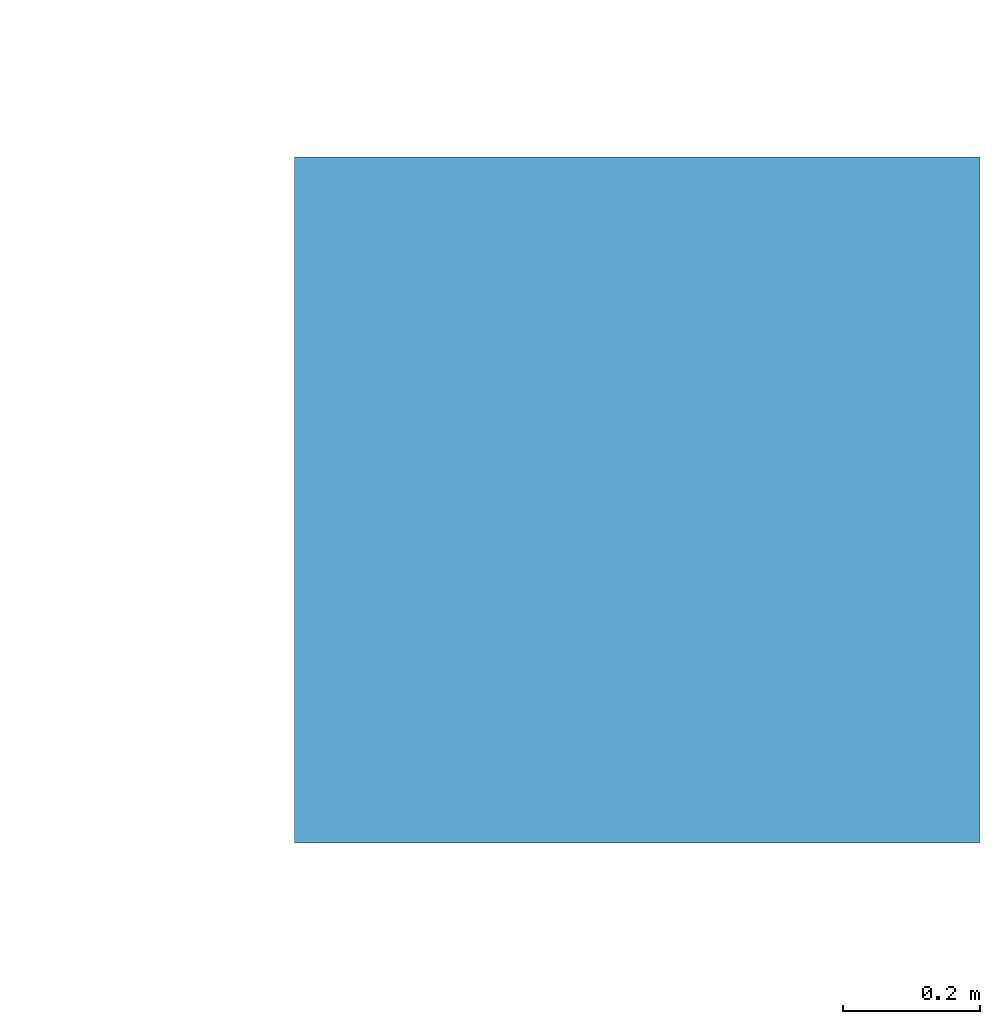
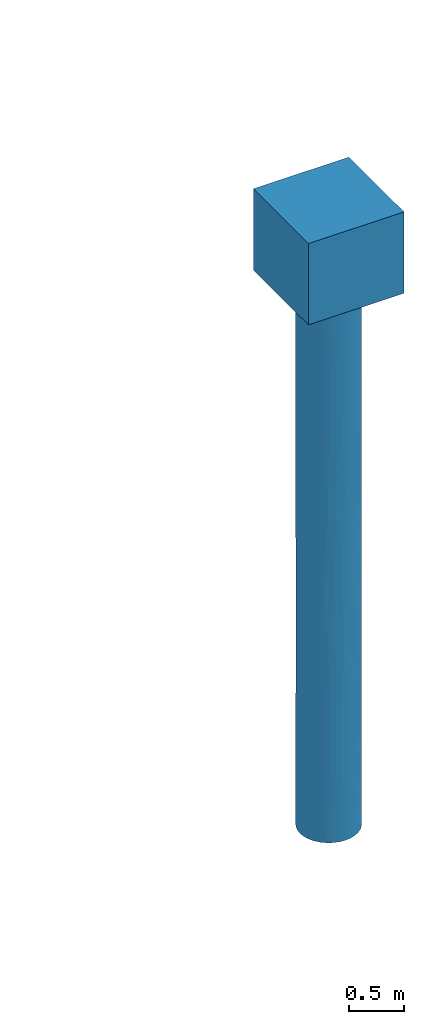
# One storey, part 2 of 2: 1 pile.
"""IFC4 building model written with IfcOpenShell, lengths in metres."""

from ifc_helpers import new_model, entity, si_unit, converted_unit, derived_unit, direction, frame, origin, place, context, subcontext, project, spatial, polygons, source, transform, mapped, material, type_object, type_shapes, element, save


model = new_model("IFC4")

# Units and contexts
model_context = context("Model", 3, precision=1e-05, world=origin(), true_north=direction((6.12303176911189e-17, 1.0)))
body_context = subcontext(model_context, "Body", "Model", "MODEL_VIEW")
ifc_project = project(units=[si_unit("LENGTHUNIT", "METRE"), si_unit("AREAUNIT", "SQUARE_METRE"), si_unit("VOLUMEUNIT", "CUBIC_METRE"), converted_unit("PLANEANGLEUNIT", "DEGREE", entity("IfcRatioMeasure", 0.0174532925199433), si_unit("PLANEANGLEUNIT", "RADIAN"), dimensions=[0, 0, 0, 0, 0, 0, 0]), si_unit("MASSUNIT", "GRAM", prefix="KILO"), derived_unit("MASSDENSITYUNIT", [(si_unit("MASSUNIT", "GRAM", prefix="KILO"), 1), (si_unit("LENGTHUNIT", "METRE"), -3)]), derived_unit("MOMENTOFINERTIAUNIT", [(si_unit("LENGTHUNIT", "METRE"), 4)]), si_unit("TIMEUNIT", "SECOND"), si_unit("FREQUENCYUNIT", "HERTZ"), si_unit("THERMODYNAMICTEMPERATUREUNIT", "DEGREE_CELSIUS"), derived_unit("THERMALTRANSMITTANCEUNIT", [(si_unit("MASSUNIT", "GRAM", prefix="KILO"), 1), (si_unit("THERMODYNAMICTEMPERATUREUNIT", "KELVIN"), -1), (si_unit("TIMEUNIT", "SECOND"), -3)]), derived_unit("VOLUMETRICFLOWRATEUNIT", [(si_unit("LENGTHUNIT", "METRE"), 3), (si_unit("TIMEUNIT", "SECOND"), -1)]), si_unit("ELECTRICCURRENTUNIT", "AMPERE"), si_unit("ELECTRICVOLTAGEUNIT", "VOLT"), si_unit("POWERUNIT", "WATT"), si_unit("FORCEUNIT", "NEWTON", prefix="KILO"), si_unit("ILLUMINANCEUNIT", "LUX"), si_unit("LUMINOUSFLUXUNIT", "LUMEN"), si_unit("LUMINOUSINTENSITYUNIT", "CANDELA"), derived_unit("USERDEFINED", [(si_unit("MASSUNIT", "GRAM", prefix="KILO"), -1), (si_unit("LENGTHUNIT", "METRE"), -2), (si_unit("TIMEUNIT", "SECOND"), 3), (si_unit("LUMINOUSFLUXUNIT", "LUMEN"), 1)]), derived_unit("LINEARVELOCITYUNIT", [(si_unit("LENGTHUNIT", "METRE"), 1), (si_unit("TIMEUNIT", "SECOND"), -1)]), si_unit("PRESSUREUNIT", "PASCAL"), derived_unit("USERDEFINED", [(si_unit("LENGTHUNIT", "METRE"), -2), (si_unit("MASSUNIT", "GRAM", prefix="KILO"), 1), (si_unit("TIMEUNIT", "SECOND"), -2)]), derived_unit("LINEARFORCEUNIT", [(si_unit("MASSUNIT", "GRAM", prefix="KILO"), 1), (si_unit("LENGTHUNIT", "METRE"), 1), (si_unit("TIMEUNIT", "SECOND"), -2), (si_unit("LENGTHUNIT", "METRE"), -1)]), derived_unit("PLANARFORCEUNIT", [(si_unit("MASSUNIT", "GRAM", prefix="KILO"), 1), (si_unit("LENGTHUNIT", "METRE"), 1), (si_unit("TIMEUNIT", "SECOND"), -2), (si_unit("LENGTHUNIT", "METRE"), -2)])], contexts=[model_context])

# Site, building, storey
site_placement = place(None, origin())
site = spatial("IfcSite", under=ifc_project, at=site_placement, CompositionType="ELEMENT")
building_placement = place(site_placement, origin())
building = spatial("IfcBuilding", under=site, at=building_placement, Name="1", CompositionType="ELEMENT")
storey_placement = place(building_placement, origin())
storey = spatial("IfcBuildingStorey", under=building, at=storey_placement, Name="1 korrus", CompositionType="ELEMENT", Elevation=0.0)

# Pile
ifc_material = material(Name="EST. C30/37", Category="Materials")
pile_type = type_object("IfcPileType", PredefinedType="NOTDEFINED", material=ifc_material)
shared_shape = source(origin(), body_context, "Body", "Tessellation", [
    polygons([(0.500000000000011, 0.5, 0.9), (-0.499999999999989, 0.5, 0.9), (-0.499999999999989, -0.5, 0.9), (0.500000000000011, -0.5, 0.9), (0.30000000000001, -1.96269667185334e-15, -6.0), (0.294235584120979, -0.0585270966048404, -6.0), (0.277163859753395, -0.114805029709529, -6.0), (0.249440883690773, -0.166671069905882, -6.0), (0.212132034355973, -0.212132034355965, -6.0), (0.166671069905889, -0.249440883690764, -6.0), (0.114805029709536, -0.277163859753387, -6.0), (0.0585270966048471, -0.294235584120969, -6.0), (8.86597462113059e-15, -0.3, -6.0), (-0.0585270966048297, -0.294235584120969, -6.0), (-0.114805029709518, -0.277163859753386, -6.0), (-0.166671069905872, -0.249440883690763, -6.0), (-0.212132034355955, -0.212132034355963, -6.0), (-0.249440883690754, -0.16667106990588, -6.0), (-0.277163859753376, -0.114805029709526, -6.0), (-0.294235584120959, -0.0585270966048374, -6.0), (-0.29999999999999, -9.47508738136094e-16, -6.0), (-0.294235584120959, 0.0585270966048374, -6.0), (-0.277163859753376, 0.114805029709526, -6.0), (-0.249440883690754, 0.16667106990588, -6.0), (-0.212132034355955, 0.212132034355963, -6.0), (-0.166671069905872, 0.249440883690763, -6.0), (-0.114805029709518, 0.277163859753386, -6.0), (-0.0585270966048297, 0.294235584120969, -6.0), (8.86597462113059e-15, 0.3, -6.0), (0.0585270966048471, 0.294235584120969, -6.0), (0.114805029709536, 0.277163859753387, -6.0), (0.166671069905889, 0.249440883690765, -6.0), (0.212132034355973, 0.212132034355965, -6.0), (0.249440883690773, 0.166671069905882, -6.0), (0.277163859753395, 0.114805029709529, -6.0), (0.294235584120979, 0.0585270966048404, -6.0), (0.500000000000011, 0.5, 0.0), (-0.499999999999989, 0.5, -1.35358391162299e-16), (-0.499999999999989, -0.5, -1.35358391162299e-16), (0.500000000000011, -0.5, -1.35358391162299e-16), (-0.29999999999999, -9.69326744659079e-16, 0.0), (-0.294235584120959, -0.0585270966048394, 0.0), (-0.277163859753375, -0.114805029709528, 0.0), (-0.249440883690753, -0.166671069905881, 0.0), (-0.212132034355954, -0.212132034355965, 0.0), (-0.16667106990587, -0.249440883690764, 0.0), (-0.114805029709516, -0.277163859753386, 0.0), (-0.0585270966048277, -0.294235584120969, 0.0), (1.06933129018216e-14, -0.3, 0.0), (0.0585270966048491, -0.294235584120969, 0.0), (0.114805029709537, -0.277163859753386, 0.0), (0.166671069905891, -0.249440883690763, 0.0), (0.212132034355975, -0.212132034355964, 0.0), (0.249440883690774, -0.166671069905881, 0.0), (0.277163859753396, -0.114805029709527, 0.0), (0.294235584120979, -0.0585270966048384, 0.0), (0.30000000000001, 1.93865348931914e-15, 0.0), (0.294235584120979, 0.0585270966048404, 0.0), (0.277163859753396, 0.114805029709529, 0.0), (0.249440883690773, 0.166671069905882, 0.0), (0.212132034355973, 0.212132034355965, 0.0), (0.166671069905889, 0.249440883690765, 0.0), (0.114805029709536, 0.277163859753387, 0.0), (0.0585270966048472, 0.294235584120969, 0.0), (8.83213502334002e-15, 0.3, 0.0), (-0.0585270966048297, 0.294235584120969, 0.0), (-0.114805029709518, 0.277163859753386, 0.0), (-0.166671069905872, 0.249440883690763, 0.0), (-0.212132034355955, 0.212132034355963, 0.0), (-0.249440883690754, 0.16667106990588, 0.0), (-0.277163859753376, 0.114805029709526, 0.0), (-0.294235584120959, 0.0585270966048375, 0.0), (0.30000000000001, 0.0, -3.58087616759201), (0.0294051411009087, -0.29855541809995, -2.99999999994958), (-0.29999999999999, -9.69326744659552e-16, -2.41912381490379), (0.231903134769796, -0.190317986758863, -2.60855789319398), (-0.190317985616317, -0.23190313570744, -3.21830624548826), (0.30000000000001, 0.0, -2.41912383240799), (0.141419020154583, -0.264576379781946, -4.19483481984957), (-0.0870854036349578, -0.287082100580539, -1.80516517837818), (-0.29999999999999, -9.69326744659552e-16, -3.58087618509621), (-0.264576379427008, -0.141419020818596, -1.8150674437864), (0.141419020222859, -0.264576379745452, -1.6552374337107), (0.264576378673259, -0.141419022228799, -4.25029038681843), (-0.0870854036119427, -0.287082100587521, -4.28003869701393), (-0.264576379419968, -0.141419020831767, -4.28003869848635), (0.26457637885215, -0.141419021894117, -1.37447063855659), (-0.190317985456949, -0.23190313583823, -4.63109408472127), (-0.190317985464988, -0.231903135831633, -1.40973592391685), (0.0294051415580735, -0.298555418054924, -1.38070887768066), (0.0294051415569467, -0.298555418055035, -4.60774252342404), (0.30000000000001, 0.0, -4.79043808379601), (-0.29999999999999, -9.69326744659552e-16, -1.2095619074519), (0.30000000000001, 0.0, -1.20956191620399), (-0.29999999999999, -9.69326744659552e-16, -4.79043809254811), (0.190317984726382, -0.231903136437808, -4.99598674432061), (-0.287082100759008, -0.0870854030465998, -1.00841102444969), (0.287082100609238, -0.0870854035403945, -5.02049977119595), (-0.287082100757004, -0.0870854030532068, -5.03356398446955), (0.190317984765417, -0.231903136405773, -0.938236748039156), (-0.0870854034128659, -0.28708210064791, -0.868772366550532), (-0.231903136103424, -0.190317985133807, -0.834749810580703), (-0.0870854033995961, -0.287082100651935, -5.17550447042091), (-0.231903136100594, -0.190317985137255, -5.18179124084353), (0.087085402793804, -0.287082100835706, -0.822966831493305), (0.0870854027920236, -0.287082100836246, -5.17235887198159), (0.287082100633177, -0.0870854034614758, -0.820449589886377), (0.283516816337299, -0.098072497949059, -2.99999999899951), (0.291949854167597, -0.0690310267309187, -1.81792823853856), (-0.283693420994263, -0.0975604575869024, -2.99999999997832), (0.212513603933638, -0.211749777197383, -3.98036979815537), (0.164598910875886, -0.25081307489538, -3.06791733361438), (-0.292389845318822, -0.0671429695085727, -4.10575939773616), (0.292377040182398, -0.0671987081288497, -4.09690516353736), (0.203210459755944, -0.220693246488836, -1.83476255926076), (-0.29232800697346, -0.0674116928946197, -1.9236528010366), (-0.0349842164411597, -0.297953191961418, -4.72777158352201), (-0.0185462670936242, -0.299426177841704, -3.78111423691226), (-0.100913805720729, -0.282517970782315, -3.05682031857561), (-0.0294051422994351, -0.298555417981904, -5.41011761550489), (0.0529547880627854, -0.295289333402388, -3.80387126149421), (0.0995258091983045, -0.283009917323448, -3.15172058828868), (0.0775873148805127, -0.289793389451233, -2.20584479763021), (-0.136309669502042, -0.267244595829815, -4.72777158416289), (-0.147242928336774, -0.261380029946453, -3.85290546044967), (-0.141419021174606, -0.264576379236721, -5.41002159577995), (0.00647415112270779, -0.299930134143338, -2.19035443824404), (-0.0372848643219461, -0.29767404806683, -2.8162038655339), (0.256757112032636, -0.155163737453909, -5.12256606586461), (0.0870916824355022, -0.287080195852231, -4.40155215752235), (-0.029313361823715, -0.298564443326045, -1.59653901718052), (-0.018183592328273, -0.299448421218144, -0.789174289150144), (0.270467859433431, -0.129796521577057, -2.23087232010598), (-0.135696882531279, -0.267556267112713, -1.33696877200696), (-0.15769699608896, -0.255209046517782, -2.31402108489463), (-0.141419021183053, -0.264576379232206, -0.62502459887626), (-0.223115978099535, -0.200547401670237, -2.35735537620157), (-0.247057076011839, -0.170184609152753, -3.24364691540981), (-0.219846200201593, -0.20412654961302, -3.92470016554962), (0.249768719992055, -0.166179380530605, -3.42644039383822), (0.264209046136207, -0.142104116547695, -0.645174578346389), (0.234194708889991, -0.187490901987102, -1.01805377525329), (0.243047649951306, -0.175863128179708, -1.90366489344064), (0.211905926545959, -0.212357901418108, -3.24904014206829), (0.165722704831474, -0.250071959850247, -2.32174130316973), (-0.232653325143195, -0.189400185585469, -1.56391936186859), (-0.190792300287052, -0.231513062592959, -5.3405138366505), (-0.0817443583424867, -0.288648332541821, -2.45202885437497), (-0.265783365035766, -0.139137352534319, -0.675168601937298), (-0.264087885081992, -0.142329157072313, -4.99215075040327), (0.140989484605523, -0.264805523414206, -0.950618128827256), (0.143685181817157, -0.263352555571753, -5.32625774251806), (-0.278057193959229, -0.112624139896888, -3.68141374922171), (0.278463836383965, -0.111614926539106, -3.6742874432391), (0.0305383875386413, -0.298441630619021, -5.37065276935231), (0.0882249144204751, -0.286733961147789, -1.52056791762359), (0.0351276258404144, -0.297936318536053, -0.749666498881476), (-0.191288460385876, -0.231103277612407, -0.630476959727301), (-0.258864134654159, -0.1516224250886, -2.54646817842518), (-0.236035511583906, -0.185168132440005, -4.5208796542628), (-0.0870854030220546, 0.287082100766461, -2.99999999999487), (0.190317985331104, 0.231903135941525, -2.99999999999698), (0.30000000000001, 2.73801406704922e-15, -3.0), (-0.264576379213315, 0.141419021218388, -2.19949799584507), (-0.23190313591053, 0.190317985368849, -4.05157138688596), (0.0294051421903708, 0.298555417992648, -1.80516517954853), (0.0294051421888379, 0.298555417992799, -4.19483482046059), (0.264576379333426, 0.141419020993714, -4.19483482052139), (0.264576379333932, 0.141419020992768, -1.80516517948546), (-0.141419020953595, 0.264576379354854, -1.56103303607225), (-0.29999999999999, -9.69326744659552e-16, -1.79043809225428), (-0.141419020961096, 0.264576379350845, -4.55592216682982), (0.141419021103589, 0.264576379274692, -1.40973592370873), (0.141419021102683, 0.264576379275176, -4.59026407628894), (0.30000000000001, 3.13769435591427e-15, -4.5), (0.30000000000001, 2.33833377818416e-15, -1.5), (-0.231903135943767, 0.19031798532835, -1.18299486035895), (-0.287082100682868, 0.0870854032975994, -1.16792564872763), (-0.264576379256062, 0.141419021138414, -4.93181298797219), (-0.0294051420391683, 0.298555418007538, -1.00401325666032), (-0.0294051420400762, 0.298555418007449, -4.99598674334194), (0.231903136033892, 0.190317985218558, -4.99598674343902), (0.231903136034292, 0.190317985218069, -1.00401325656304), (0.287082100729628, 0.0870854031435208, -4.99598674354478), (0.287082100729789, 0.0870854031429909, -1.00401325645761), (-0.190317985197103, 0.23190313605148, -5.15116798136727), (0.0870854032171954, 0.287082100707272, -0.834749810531415), (0.0870854032165748, 0.28708210070746, -5.16525018946618), (-0.141419020999746, 0.264576379330186, -0.741418667687219), (-0.282378255696193, 0.101304100163665, -3.80069745205816), (-0.0577127523130707, 0.294396396412132, -2.00545378697209), (0.000542908221253977, 0.299999508750703, -2.818761168691), (0.102717541248656, 0.28186717921715, -2.67254353369385), (-0.0577127523144487, 0.294396396411861, -3.99454621302766), (0.212718170287613, 0.211544274395443, -3.99454621318084), (0.249742098841936, 0.166219385349694, -3.18123883188893), (0.28777400526894, 0.0847709967587843, -3.38390905779615), (0.212718170288315, 0.211544274394737, -2.0054537868199), (0.291866084547861, 0.0693843547978001, -2.33992465565964), (-0.205338245904352, 0.218714893797655, -2.2487271502536), (-0.0912974388295615, 0.28577049823794, -1.15122585176078), (-0.186399456080391, 0.235064337518328, -1.15122585196907), (-0.29999999999999, -9.69326744659552e-16, -2.68565713838142), (-0.292138006414461, 0.0682303833213507, -2.23804761540379), (-0.279850510297896, 0.108091127693265, -2.94326928877901), (-0.239832014926779, 0.180223762629006, -3.01842190024081), (-0.171811866618341, 0.245928205964907, -3.28726934778664), (-0.294529656469331, 0.0570287774728864, -3.31305187801309), (0.157206808326282, 0.255511290192561, -3.73652207303471), (0.0962675799043705, 0.284134744548001, -3.98823105509223), (0.0488286658135205, 0.295999596950524, -3.40613755891913), (-0.01115284538864, 0.299792618387673, -3.53019887663076), (-0.13844108709766, 0.266146699027464, -5.31056322919057), (-0.090215324729299, 0.286113954892077, -4.89937703038621), (-0.192615586337078, 0.229998338907088, -4.40184792285927), (-0.229921990328855, 0.192706715926595, -4.80694705059196), (-0.159857134035115, 0.253861569951177, -3.93540916007591), (-0.110890758299492, 0.27875300845688, -4.03117689556077), (0.143249017457243, 0.263590058609079, -0.667685754061062), (0.187527825675856, 0.234165143856403, -1.06010702034237), (0.143249017456719, 0.263590058609363, -5.33231424593814), (0.187527825675285, 0.23416514385686, -4.93989297965721), (0.114936603566485, 0.277109323481912, -3.34247668497577), (0.0860552174811341, 0.287392587838094, -1.56234183756813), (0.123628552210641, 0.273342241664737, -2.04764194905906), (0.170753368761951, 0.246664320598761, -1.92257185319157), (-0.29999999999999, -9.69326744659552e-16, -0.89521904612714), (-0.264391663254119, 0.141764058920854, -0.744902209502586), (-0.263340134875405, 0.143707944678775, -1.47229118849246), (-0.291407238083391, 0.0712868963597377, -5.10381248151206), (-0.295018406220883, 0.0544439160134916, -4.34081287823829), (0.264576379316762, 0.14141902102489, -5.31562615038714), (0.30000000000001, 3.3375345003468e-15, -5.25), (0.264576379323732, 0.14141902101185, -1.09986281499958), (0.30000000000001, 2.13849363375163e-15, -0.75), (0.0310633210717941, 0.298387449608711, -1.08261882773878), (0.0269111812350197, 0.29879054256207, -5.32596677576019), (-0.117662917557893, 0.27596274718114, -2.29837403333874), (-0.163602111686555, 0.251464409115279, -2.12560623224129), (0.30000000000001, 2.93785421148174e-15, -3.75), (0.246201575967339, 0.171419905469592, -2.43186954184727), (0.274665806240877, 0.120659416880965, -2.74140742304519), (0.286613841139223, 0.0886143671614606, -1.69277108263208), (0.30000000000001, 2.53817392261669e-15, -2.25), (0.292711516576649, 0.0657264639502554, -4.19435183968803)], [[[4, 1, 2, 3]], [[22, 23, 24, 25, 26, 27, 28, 29, 30, 31, 32, 33, 34, 35, 36, 5, 6, 7, 8, 9, 10, 11, 12, 13, 14, 15, 16, 17, 18, 19, 20, 21]], [[38, 37, 40, 39], [66, 67, 68, 69, 70, 71, 72, 41, 42, 43, 44, 45, 46, 47, 48, 49, 50, 51, 52, 53, 54, 55, 56, 57, 58, 59, 60, 61, 62, 63, 64, 65]], [[2, 1, 37, 38]], [[3, 2, 38, 39]], [[4, 3, 39, 40]], [[1, 4, 40, 37]], [[84, 98, 114]], [[99, 113, 95]], [[142, 53, 100]], [[96, 111, 79]], [[53, 52, 100]], [[117, 118, 85]], [[132, 90, 157]], [[89, 134, 136]], [[142, 115, 143]], [[110, 75, 203, 81]], [[52, 51, 151]], [[107, 56, 55]], [[118, 121, 74]], [[152, 10, 96]], [[96, 10, 9]], [[108, 73, 163, 78]], [[132, 131, 90]], [[82, 146, 149]], [[109, 94, 107]], [[82, 97, 116]], [[74, 122, 123]], [[98, 129, 7]], [[130, 152, 79]], [[8, 7, 129]], [[99, 20, 19]], [[79, 111, 112]], [[50, 105, 51]], [[87, 107, 141]], [[155, 91, 117]], [[150, 19, 18]], [[103, 117, 85]], [[119, 85, 118]], [[149, 43, 97]], [[102, 45, 44]], [[158, 45, 102]], [[132, 48, 101]], [[134, 80, 101]], [[135, 137, 77]], [[141, 55, 54]], [[109, 133, 108]], [[42, 97, 43]], [[103, 124, 126]], [[105, 151, 51]], [[150, 18, 104]], [[139, 77, 138]], [[16, 126, 147]], [[106, 155, 12]], [[48, 47, 101]], [[74, 121, 122]], [[124, 125, 88]], [[15, 14, 103]], [[132, 157, 49]], [[84, 114, 154]], [[89, 136, 158]], [[15, 126, 16]], [[147, 126, 124]], [[159, 137, 82]], [[77, 125, 119]], [[18, 17, 104]], [[117, 120, 155]], [[110, 159, 116]], [[7, 6, 98]], [[129, 9, 8]], [[123, 127, 74]], [[106, 12, 11]], [[89, 135, 134]], [[129, 98, 84]], [[6, 5, 233, 92]], [[56, 94, 235, 57]], [[42, 41, 227, 93]], [[95, 21, 20]], [[96, 129, 111]], [[42, 93, 97]], [[116, 93, 171, 75]], [[6, 92, 98]], [[114, 92, 175, 240, 73]], [[113, 99, 86]], [[95, 20, 99]], [[115, 100, 83]], [[142, 87, 141]], [[47, 46, 136]], [[101, 80, 131]], [[44, 43, 149]], [[146, 89, 102]], [[14, 13, 120]], [[124, 103, 85]], [[160, 88, 139]], [[99, 150, 86]], [[156, 90, 123]], [[100, 151, 83]], [[11, 10, 152]], [[121, 130, 79]], [[109, 107, 87]], [[94, 56, 107]], [[108, 78, 109]], [[76, 144, 140]], [[109, 87, 133]], [[109, 78, 244, 176, 94]], [[113, 110, 81]], [[137, 138, 77]], [[140, 111, 84]], [[111, 140, 144]], [[145, 76, 115]], [[122, 112, 145]], [[153, 113, 86]], [[95, 113, 81]], [[92, 114, 98]], [[108, 114, 73]], [[145, 115, 83]], [[76, 133, 143]], [[93, 116, 97]], [[110, 116, 75]], [[103, 14, 120]], [[91, 121, 118]], [[91, 118, 117]], [[74, 127, 128]], [[128, 118, 74]], [[135, 80, 134]], [[12, 155, 13]], [[103, 120, 117]], [[130, 121, 91]], [[122, 79, 112]], [[79, 122, 121]], [[145, 123, 122]], [[156, 123, 83]], [[127, 123, 90]], [[125, 124, 85]], [[104, 147, 88]], [[119, 125, 85]], [[125, 77, 139]], [[103, 126, 15]], [[147, 124, 88]], [[90, 131, 127]], [[128, 148, 119]], [[127, 131, 148]], [[118, 128, 119]], [[111, 129, 84]], [[9, 129, 96]], [[91, 106, 130]], [[152, 130, 106]], [[157, 90, 105]], [[148, 131, 80]], [[48, 132, 49]], [[101, 131, 132]], [[143, 133, 87]], [[140, 133, 76]], [[101, 47, 136]], [[137, 89, 146]], [[77, 119, 135]], [[135, 119, 148]], [[45, 158, 46]], [[101, 136, 134]], [[89, 137, 135]], [[137, 159, 138]], [[153, 138, 110]], [[86, 160, 139]], [[86, 139, 138]], [[125, 139, 88]], [[154, 140, 84]], [[133, 140, 108]], [[55, 141, 107]], [[54, 53, 142]], [[142, 141, 54]], [[115, 142, 100]], [[142, 143, 87]], [[76, 143, 115]], [[145, 144, 76]], [[112, 111, 144]], [[123, 145, 83]], [[145, 112, 144]], [[149, 146, 102]], [[137, 146, 82]], [[104, 17, 147]], [[16, 147, 17]], [[127, 148, 128]], [[135, 148, 80]], [[82, 149, 97]], [[44, 149, 102]], [[19, 150, 99]], [[160, 150, 104]], [[52, 151, 100]], [[156, 151, 105]], [[79, 152, 96]], [[11, 152, 106]], [[138, 153, 86]], [[110, 113, 153]], [[114, 108, 154]], [[140, 154, 108]], [[91, 155, 106]], [[13, 155, 120]], [[151, 156, 83]], [[90, 156, 105]], [[105, 50, 157]], [[49, 157, 50]], [[89, 158, 102]], [[46, 158, 136]], [[116, 159, 82]], [[110, 138, 159]], [[150, 160, 86]], [[88, 160, 104]], [[177, 228, 70]], [[197, 199, 163]], [[203, 204, 208]], [[71, 70, 228]], [[178, 72, 71]], [[177, 202, 200]], [[213, 186, 172]], [[210, 223, 209]], [[180, 201, 66]], [[202, 68, 189]], [[67, 189, 68]], [[182, 195, 168]], [[233, 36, 184]], [[65, 180, 66]], [[69, 68, 202]], [[236, 64, 187]], [[237, 167, 188]], [[72, 227, 41]], [[179, 230, 231]], [[215, 216, 165]], [[232, 168, 184]], [[21, 230, 22]], [[21, 95, 230]], [[23, 179, 24]], [[179, 216, 24]], [[226, 220, 198]], [[186, 26, 25]], [[242, 169, 199]], [[28, 27, 214]], [[234, 60, 59]], [[64, 236, 65]], [[229, 204, 178]], [[170, 201, 191]], [[227, 72, 178]], [[187, 64, 63]], [[179, 190, 165]], [[60, 183, 61]], [[181, 194, 167]], [[184, 35, 232]], [[196, 197, 168]], [[185, 59, 58]], [[229, 178, 228]], [[169, 183, 234]], [[168, 232, 182]], [[207, 206, 200]], [[172, 215, 217]], [[59, 185, 234]], [[181, 29, 28]], [[187, 219, 173]], [[62, 219, 63]], [[181, 237, 29]], [[174, 221, 188]], [[26, 186, 213]], [[192, 161, 191]], [[30, 188, 31]], [[222, 33, 32]], [[34, 33, 182]], [[35, 184, 36]], [[168, 195, 196]], [[182, 232, 34]], [[31, 188, 221]], [[177, 70, 69]], [[193, 223, 211]], [[58, 235, 185]], [[183, 220, 61]], [[225, 193, 224]], [[164, 229, 200]], [[230, 23, 22]], [[81, 208, 231]], [[191, 180, 166]], [[201, 170, 189]], [[214, 27, 213]], [[217, 218, 172]], [[222, 32, 221]], [[174, 209, 195]], [[198, 183, 169]], [[220, 173, 219]], [[168, 197, 245]], [[233, 5, 36]], [[235, 58, 57]], [[65, 236, 180]], [[168, 245, 184]], [[25, 24, 216]], [[215, 172, 186]], [[173, 224, 187]], [[180, 236, 166]], [[30, 29, 237]], [[210, 188, 167]], [[67, 66, 201]], [[202, 189, 170]], [[204, 203, 75, 171]], [[190, 205, 206]], [[192, 191, 166]], [[191, 161, 238]], [[193, 192, 166]], [[192, 211, 212]], [[193, 166, 224]], [[162, 195, 209]], [[194, 181, 214]], [[212, 161, 192]], [[195, 182, 222]], [[196, 195, 162]], [[241, 162, 198]], [[197, 196, 242]], [[196, 241, 242]], [[240, 175, 245]], [[241, 198, 169]], [[162, 193, 225]], [[243, 199, 169]], [[199, 176, 244, 78, 163]], [[170, 191, 238]], [[164, 206, 205]], [[201, 189, 67]], [[191, 201, 180]], [[202, 170, 239]], [[69, 202, 177]], [[205, 208, 204]], [[178, 204, 171]], [[205, 204, 164]], [[164, 200, 206]], [[205, 190, 208]], [[170, 238, 239]], [[190, 206, 165]], [[194, 218, 161]], [[165, 206, 207]], [[231, 208, 190]], [[203, 208, 81]], [[210, 209, 174]], [[162, 209, 223]], [[188, 210, 174]], [[210, 167, 211]], [[212, 167, 194]], [[193, 211, 192]], [[167, 212, 211]], [[161, 212, 194]], [[214, 213, 172]], [[26, 213, 27]], [[214, 172, 218]], [[28, 214, 181]], [[216, 215, 186]], [[217, 165, 207]], [[216, 186, 25]], [[165, 216, 179]], [[165, 217, 215]], [[207, 161, 218]], [[218, 217, 207]], [[214, 218, 194]], [[63, 219, 187]], [[62, 61, 220]], [[220, 219, 62]], [[198, 220, 183]], [[222, 221, 174]], [[31, 221, 32]], [[195, 222, 174]], [[33, 222, 182]], [[211, 223, 210]], [[162, 223, 193]], [[224, 173, 225]], [[236, 224, 166]], [[173, 226, 225]], [[225, 226, 162]], [[220, 226, 173]], [[162, 226, 198]], [[178, 171, 93, 227]], [[229, 228, 177]], [[71, 228, 178]], [[200, 229, 177]], [[229, 164, 204]], [[231, 230, 95]], [[23, 230, 179]], [[81, 231, 95]], [[179, 231, 190]], [[34, 232, 35]], [[184, 175, 92, 233]], [[185, 235, 94, 176]], [[234, 183, 60]], [[243, 234, 185]], [[224, 236, 187]], [[167, 237, 181]], [[30, 237, 188]], [[161, 207, 238]], [[239, 207, 200]], [[207, 239, 238]], [[202, 239, 200]], [[184, 245, 175]], [[197, 163, 73, 240]], [[162, 241, 196]], [[169, 242, 241]], [[197, 242, 199]], [[234, 243, 169]], [[176, 243, 185]], [[176, 199, 243]], [[240, 245, 197]]], closed=True),
])
type_shapes(pile_type, [shared_shape])
pile_placement = place(storey_placement, frame((21.0, 5.05750003622706, 0.0)))
element("IfcPile", 1, at=pile_placement, inside=storey, type_object=pile_type, material=ifc_material, PredefinedType="NOTDEFINED", context=body_context, shape_type="MappedRepresentation", body=[
    mapped(shared_shape, transform((0.0, 0.0, 0.0), scale=1.0)),
])

save(model, "model.ifc")
